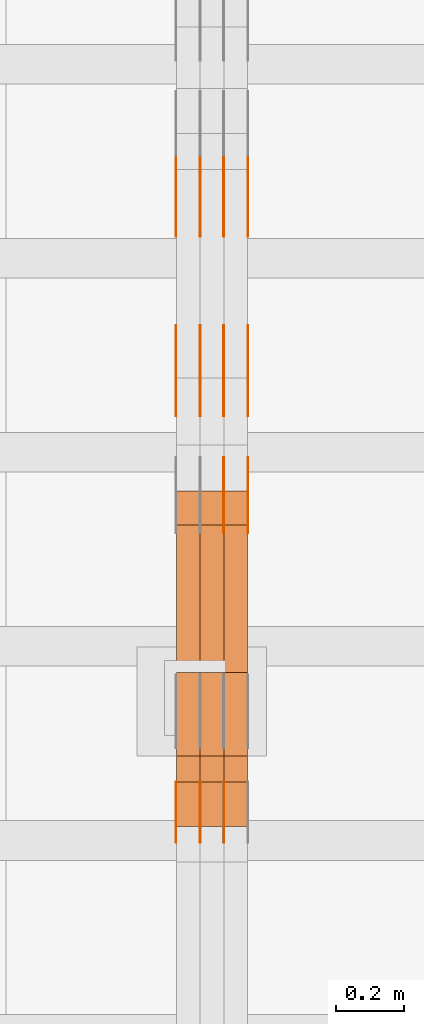
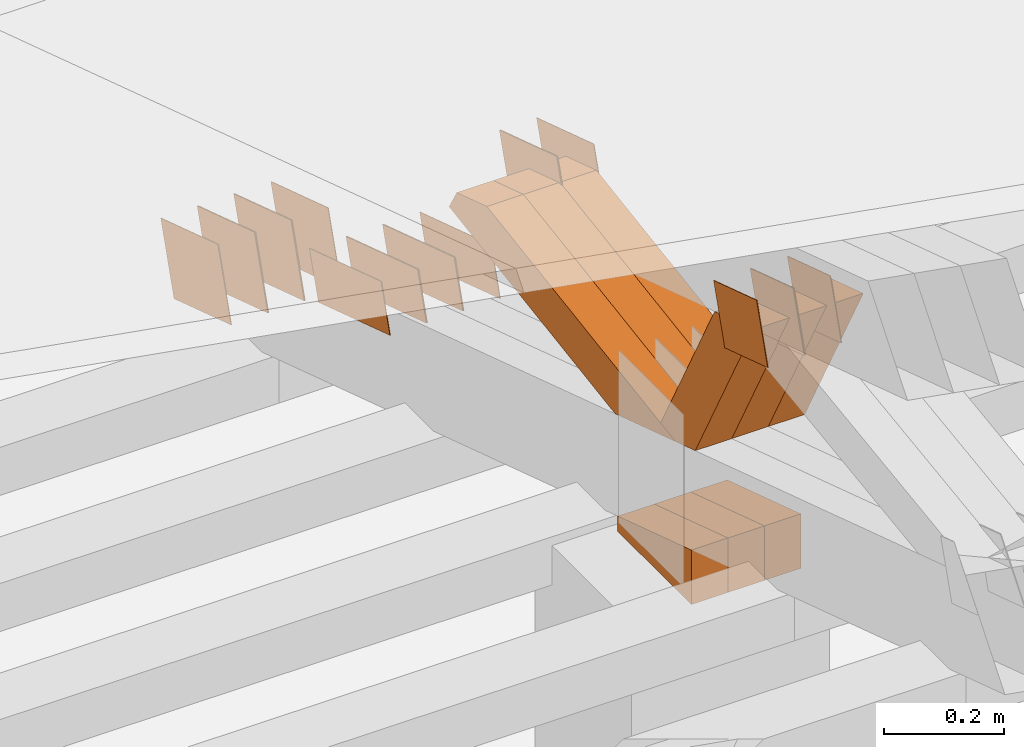
# One storey, part 301 of 385: 28 proxies.
"""IFC2X3 building model written with IfcOpenShell, lengths in millimetres."""

from ifc_helpers import new_model, entity, si_unit, converted_unit, derived_unit, direction, frame, origin, place, context, subcontext, project, spatial, polyline, outline, extrude, source, transform, mapped, material, type_object, type_shapes, element, save


model = new_model("IFC2X3")

# Units and contexts
model_context = context("Model", 3, precision=0.01, world=origin(), true_north=direction((6.12303176911189e-17, 1.0)))
body_context = subcontext(model_context, "Body", "Model", "MODEL_VIEW")
ifc_project = project(units=[si_unit("LENGTHUNIT", "METRE", prefix="MILLI"), si_unit("AREAUNIT", "SQUARE_METRE"), si_unit("VOLUMEUNIT", "CUBIC_METRE"), converted_unit("PLANEANGLEUNIT", "DEGREE", entity("IfcRatioMeasure", 0.0174532925199433), si_unit("PLANEANGLEUNIT", "RADIAN"), dimensions=[0, 0, 0, 0, 0, 0, 0]), si_unit("MASSUNIT", "GRAM", prefix="KILO"), derived_unit("MASSDENSITYUNIT", [(si_unit("MASSUNIT", "GRAM", prefix="KILO"), 1), (si_unit("LENGTHUNIT", "METRE"), -3)]), si_unit("TIMEUNIT", "SECOND"), si_unit("FREQUENCYUNIT", "HERTZ"), si_unit("THERMODYNAMICTEMPERATUREUNIT", "DEGREE_CELSIUS"), derived_unit("THERMALTRANSMITTANCEUNIT", [(si_unit("MASSUNIT", "GRAM", prefix="KILO"), 1), (si_unit("THERMODYNAMICTEMPERATUREUNIT", "KELVIN"), -1), (si_unit("TIMEUNIT", "SECOND"), -3)]), derived_unit("VOLUMETRICFLOWRATEUNIT", [(si_unit("LENGTHUNIT", "METRE"), 3), (si_unit("TIMEUNIT", "SECOND"), -1)]), si_unit("ELECTRICCURRENTUNIT", "AMPERE"), si_unit("ELECTRICVOLTAGEUNIT", "VOLT"), si_unit("POWERUNIT", "WATT"), si_unit("FORCEUNIT", "NEWTON", prefix="KILO"), si_unit("ILLUMINANCEUNIT", "LUX"), si_unit("LUMINOUSFLUXUNIT", "LUMEN"), si_unit("LUMINOUSINTENSITYUNIT", "CANDELA"), derived_unit("USERDEFINED", [(si_unit("MASSUNIT", "GRAM", prefix="KILO"), -1), (si_unit("LENGTHUNIT", "METRE"), -2), (si_unit("TIMEUNIT", "SECOND"), 3), (si_unit("LUMINOUSFLUXUNIT", "LUMEN"), 1)]), derived_unit("LINEARVELOCITYUNIT", [(si_unit("LENGTHUNIT", "METRE"), 1), (si_unit("TIMEUNIT", "SECOND"), -1)]), si_unit("PRESSUREUNIT", "PASCAL"), derived_unit("USERDEFINED", [(si_unit("LENGTHUNIT", "METRE"), -2), (si_unit("MASSUNIT", "GRAM", prefix="KILO"), 1), (si_unit("TIMEUNIT", "SECOND"), -2)])], contexts=[model_context])

# Site, building, storey
site_placement = place(None, origin())
site = spatial("IfcSite", under=ifc_project, at=site_placement, CompositionType="ELEMENT")
building_placement = place(site_placement, origin())
building = spatial("IfcBuilding", under=site, at=building_placement, CompositionType="ELEMENT")
storey_placement = place(building_placement, origin())
storey = spatial("IfcBuildingStorey", under=building, at=storey_placement, Name="Default", CompositionType="ELEMENT", Elevation=0.0)

# Proxies
ifc_material_1 = material(Name="IfcSurfaceStyle #514582")
building_element_proxy_type_1 = type_object("IfcBuildingElementProxyType", PredefinedType="NOTDEFINED", material=ifc_material_1)
shared_shape_1 = source(origin(), body_context, "Body", "SweptSolid", [
    extrude(outline(polyline([(-125.00031378339, -47.9999612158856), (125.000225258022, -47.9999612158856), (124.999811678525, 47.9999612158856), (-124.999723153156, 47.9999612158856), (-125.00031378339, -47.9999612158856)])), frame((125.000225258022, 48.0000091013474, 0.0), z_axis=(0.0, 0.0, 1.0), x_axis=(-1.0, 0.0, 0.0)), (0.0, 0.0, 1.0), 1.3),
])
type_shapes(building_element_proxy_type_1, [shared_shape_1])
proxy_1_placement = place(building_placement, frame((42386.3, 18456.8597683375, 2657.46691321253), z_axis=(-1.0, 0.0, 0.0), x_axis=(0.0, -0.951056516295124, 0.309016994375039)))
element("IfcBuildingElementProxy", 1, at=proxy_1_placement, inside=storey, type_object=building_element_proxy_type_1, material=ifc_material_1, context=body_context, shape_type="MappedRepresentation", body=[
    mapped(shared_shape_1, transform((0.0, 0.0, 0.0), scale=1.0)),
])
ifc_material_2 = material(Name="IfcSurfaceStyle #514525")
building_element_proxy_type_2 = type_object("IfcBuildingElementProxyType", PredefinedType="NOTDEFINED", material=ifc_material_2)
shared_shape_2 = source(origin(), body_context, "Body", "SweptSolid", [
    extrude(outline(polyline([(-125.00031378339, -47.9999612158856), (125.000225258022, -47.9999612158856), (124.999811678525, 47.9999612158856), (-124.999723153156, 47.9999612158856), (-125.00031378339, -47.9999612158856)])), frame((125.000225258022, 48.0000091013474, 0.0), z_axis=(0.0, 0.0, 1.0), x_axis=(-1.0, 0.0, 0.0)), (0.0, 0.0, 1.0), 1.3),
])
type_shapes(building_element_proxy_type_2, [shared_shape_2])
proxy_2_placement = place(building_placement, frame((42315.0, 18456.8597683375, 2657.46691321253), z_axis=(-1.0, 0.0, 0.0), x_axis=(0.0, -0.951056516295124, 0.309016994375039)))
element("IfcBuildingElementProxy", 2, at=proxy_2_placement, inside=storey, type_object=building_element_proxy_type_2, material=ifc_material_2, context=body_context, shape_type="MappedRepresentation", body=[
    mapped(shared_shape_2, transform((0.0, 0.0, 0.0), scale=1.0)),
])
ifc_material_3 = material(Name="IfcSurfaceStyle #514468")
building_element_proxy_type_3 = type_object("IfcBuildingElementProxyType", PredefinedType="NOTDEFINED", material=ifc_material_3)
shared_shape_3 = source(origin(), body_context, "Body", "SweptSolid", [
    extrude(outline(polyline([(-125.00031378339, -47.9999612158856), (125.000225258022, -47.9999612158856), (124.999811678525, 47.9999612158856), (-124.999723153156, 47.9999612158856), (-125.00031378339, -47.9999612158856)])), frame((125.000225258022, 48.0000091013474, 0.0), z_axis=(0.0, 0.0, 1.0), x_axis=(-1.0, 0.0, 0.0)), (0.0, 0.0, 1.0), 1.3),
])
type_shapes(building_element_proxy_type_3, [shared_shape_3])
proxy_3_placement = place(building_placement, frame((42316.3, 18456.8597683375, 2657.46691321253), z_axis=(-1.0, 0.0, 0.0), x_axis=(0.0, -0.951056516295124, 0.309016994375039)))
element("IfcBuildingElementProxy", 3, at=proxy_3_placement, inside=storey, type_object=building_element_proxy_type_3, material=ifc_material_3, context=body_context, shape_type="MappedRepresentation", body=[
    mapped(shared_shape_3, transform((0.0, 0.0, 0.0), scale=1.0)),
])
ifc_material_4 = material(Name="IfcSurfaceStyle #514411")
building_element_proxy_type_4 = type_object("IfcBuildingElementProxyType", PredefinedType="NOTDEFINED", material=ifc_material_4)
shared_shape_4 = source(origin(), body_context, "Body", "SweptSolid", [
    extrude(outline(polyline([(-125.00031378339, -47.9999612158856), (125.000225258022, -47.9999612158856), (124.999811678525, 47.9999612158856), (-124.999723153156, 47.9999612158856), (-125.00031378339, -47.9999612158856)])), frame((125.000225258022, 48.0000091013474, 0.0), z_axis=(0.0, 0.0, 1.0), x_axis=(-1.0, 0.0, 0.0)), (0.0, 0.0, 1.0), 1.29999999999998),
])
type_shapes(building_element_proxy_type_4, [shared_shape_4])
proxy_4_placement = place(building_placement, frame((42245.0, 18456.8597683375, 2657.46691321253), z_axis=(-1.0, 0.0, 0.0), x_axis=(0.0, -0.951056516295124, 0.309016994375039)))
element("IfcBuildingElementProxy", 4, at=proxy_4_placement, inside=storey, type_object=building_element_proxy_type_4, material=ifc_material_4, context=body_context, shape_type="MappedRepresentation", body=[
    mapped(shared_shape_4, transform((0.0, 0.0, 0.0), scale=1.0)),
])
ifc_material_5 = material(Name="IfcSurfaceStyle #514354")
building_element_proxy_type_5 = type_object("IfcBuildingElementProxyType", PredefinedType="NOTDEFINED", material=ifc_material_5)
shared_shape_5 = source(origin(), body_context, "Body", "SweptSolid", [
    extrude(outline(polyline([(-125.00031378339, -47.9999612158856), (125.000225258022, -47.9999612158856), (124.999811678525, 47.9999612158856), (-124.999723153156, 47.9999612158856), (-125.00031378339, -47.9999612158856)])), frame((125.000225258022, 48.0000091013474, 0.0), z_axis=(0.0, 0.0, 1.0), x_axis=(-1.0, 0.0, 0.0)), (0.0, 0.0, 1.0), 1.29999999999998),
])
type_shapes(building_element_proxy_type_5, [shared_shape_5])
proxy_5_placement = place(building_placement, frame((42246.3, 18456.8597683375, 2657.46691321253), z_axis=(-1.0, 0.0, 0.0), x_axis=(0.0, -0.951056516295124, 0.309016994375039)))
element("IfcBuildingElementProxy", 5, at=proxy_5_placement, inside=storey, type_object=building_element_proxy_type_5, material=ifc_material_5, context=body_context, shape_type="MappedRepresentation", body=[
    mapped(shared_shape_5, transform((0.0, 0.0, 0.0), scale=1.0)),
])
ifc_material_6 = material(Name="IfcSurfaceStyle #514297")
building_element_proxy_type_6 = type_object("IfcBuildingElementProxyType", PredefinedType="NOTDEFINED", material=ifc_material_6)
shared_shape_6 = source(origin(), body_context, "Body", "SweptSolid", [
    extrude(outline(polyline([(-125.00031378339, -47.9999612158856), (125.000225258022, -47.9999612158856), (124.999811678525, 47.9999612158856), (-124.999723153156, 47.9999612158856), (-125.00031378339, -47.9999612158856)])), frame((125.000225258022, 48.0000091013474, 0.0), z_axis=(0.0, 0.0, 1.0), x_axis=(-1.0, 0.0, 0.0)), (0.0, 0.0, 1.0), 1.29999999999998),
])
type_shapes(building_element_proxy_type_6, [shared_shape_6])
proxy_6_placement = place(building_placement, frame((42175.0, 18456.8597683375, 2657.46691321253), z_axis=(-1.0, 0.0, 0.0), x_axis=(0.0, -0.951056516295124, 0.309016994375039)))
element("IfcBuildingElementProxy", 6, at=proxy_6_placement, inside=storey, type_object=building_element_proxy_type_6, material=ifc_material_6, context=body_context, shape_type="MappedRepresentation", body=[
    mapped(shared_shape_6, transform((0.0, 0.0, 0.0), scale=1.0)),
])
ifc_material_7 = material(Name="IfcSurfaceStyle #512872")
building_element_proxy_type_7 = type_object("IfcBuildingElementProxyType", PredefinedType="NOTDEFINED", material=ifc_material_7)
shared_shape_7 = source(origin(), body_context, "Body", "SweptSolid", [
    extrude(outline(polyline([(-99.999796294464, -72.0000050220467), (99.9998768370438, -72.0000050220467), (100.000260677528, 72.0000050220467), (-100.000341220108, 72.0000050220467), (-99.999796294464, -72.0000050220467)])), frame((100.000260677528, 72.0000050220467, 0.0), z_axis=(0.0, 0.0, 1.0), x_axis=(-1.0, 0.0, 0.0)), (0.0, 0.0, 1.0), 1.3),
])
type_shapes(building_element_proxy_type_7, [shared_shape_7])
proxy_7_placement = place(building_placement, frame((42386.3, 18936.3876569477, 2373.90613192527), z_axis=(-1.0, 0.0, 0.0), x_axis=(0.0, -0.951056516295124, 0.309016994375039)))
element("IfcBuildingElementProxy", 7, at=proxy_7_placement, inside=storey, type_object=building_element_proxy_type_7, material=ifc_material_7, context=body_context, shape_type="MappedRepresentation", body=[
    mapped(shared_shape_7, transform((0.0, 0.0, 0.0), scale=1.0)),
])
ifc_material_8 = material(Name="IfcSurfaceStyle #512815")
building_element_proxy_type_8 = type_object("IfcBuildingElementProxyType", PredefinedType="NOTDEFINED", material=ifc_material_8)
shared_shape_8 = source(origin(), body_context, "Body", "SweptSolid", [
    extrude(outline(polyline([(-99.999796294464, -72.0000050220467), (99.9998768370438, -72.0000050220467), (100.000260677528, 72.0000050220467), (-100.000341220108, 72.0000050220467), (-99.999796294464, -72.0000050220467)])), frame((100.000260677528, 72.0000050220467, 0.0), z_axis=(0.0, 0.0, 1.0), x_axis=(-1.0, 0.0, 0.0)), (0.0, 0.0, 1.0), 1.3),
])
type_shapes(building_element_proxy_type_8, [shared_shape_8])
proxy_8_placement = place(building_placement, frame((42315.0, 18936.3876569477, 2373.90613192527), z_axis=(-1.0, 0.0, 0.0), x_axis=(0.0, -0.951056516295124, 0.309016994375039)))
element("IfcBuildingElementProxy", 8, at=proxy_8_placement, inside=storey, type_object=building_element_proxy_type_8, material=ifc_material_8, context=body_context, shape_type="MappedRepresentation", body=[
    mapped(shared_shape_8, transform((0.0, 0.0, 0.0), scale=1.0)),
])
ifc_material_9 = material(Name="IfcSurfaceStyle #512758")
building_element_proxy_type_9 = type_object("IfcBuildingElementProxyType", PredefinedType="NOTDEFINED", material=ifc_material_9)
shared_shape_9 = source(origin(), body_context, "Body", "SweptSolid", [
    extrude(outline(polyline([(-99.999796294464, -72.0000050220467), (99.9998768370438, -72.0000050220467), (100.000260677528, 72.0000050220467), (-100.000341220108, 72.0000050220467), (-99.999796294464, -72.0000050220467)])), frame((100.000260677528, 72.0000050220467, 0.0), z_axis=(0.0, 0.0, 1.0), x_axis=(-1.0, 0.0, 0.0)), (0.0, 0.0, 1.0), 1.3),
])
type_shapes(building_element_proxy_type_9, [shared_shape_9])
proxy_9_placement = place(building_placement, frame((42316.3, 18936.3876569477, 2373.90613192527), z_axis=(-1.0, 0.0, 0.0), x_axis=(0.0, -0.951056516295124, 0.309016994375039)))
element("IfcBuildingElementProxy", 9, at=proxy_9_placement, inside=storey, type_object=building_element_proxy_type_9, material=ifc_material_9, context=body_context, shape_type="MappedRepresentation", body=[
    mapped(shared_shape_9, transform((0.0, 0.0, 0.0), scale=1.0)),
])
ifc_material_10 = material(Name="IfcSurfaceStyle #512701")
building_element_proxy_type_10 = type_object("IfcBuildingElementProxyType", PredefinedType="NOTDEFINED", material=ifc_material_10)
shared_shape_10 = source(origin(), body_context, "Body", "SweptSolid", [
    extrude(outline(polyline([(-99.999796294464, -72.0000050220467), (99.9998768370438, -72.0000050220467), (100.000260677528, 72.0000050220467), (-100.000341220108, 72.0000050220467), (-99.999796294464, -72.0000050220467)])), frame((100.000260677528, 72.0000050220467, 0.0), z_axis=(0.0, 0.0, 1.0), x_axis=(-1.0, 0.0, 0.0)), (0.0, 0.0, 1.0), 1.29999999999998),
])
type_shapes(building_element_proxy_type_10, [shared_shape_10])
proxy_10_placement = place(building_placement, frame((42245.0, 18936.3876569477, 2373.90613192527), z_axis=(-1.0, 0.0, 0.0), x_axis=(0.0, -0.951056516295124, 0.309016994375039)))
element("IfcBuildingElementProxy", 10, at=proxy_10_placement, inside=storey, type_object=building_element_proxy_type_10, material=ifc_material_10, context=body_context, shape_type="MappedRepresentation", body=[
    mapped(shared_shape_10, transform((0.0, 0.0, 0.0), scale=1.0)),
])
ifc_material_11 = material(Name="IfcSurfaceStyle #512644")
building_element_proxy_type_11 = type_object("IfcBuildingElementProxyType", PredefinedType="NOTDEFINED", material=ifc_material_11)
shared_shape_11 = source(origin(), body_context, "Body", "SweptSolid", [
    extrude(outline(polyline([(-99.999796294464, -72.0000050220467), (99.9998768370438, -72.0000050220467), (100.000260677528, 72.0000050220467), (-100.000341220108, 72.0000050220467), (-99.999796294464, -72.0000050220467)])), frame((100.000260677528, 72.0000050220467, 0.0), z_axis=(0.0, 0.0, 1.0), x_axis=(-1.0, 0.0, 0.0)), (0.0, 0.0, 1.0), 1.29999999999998),
])
type_shapes(building_element_proxy_type_11, [shared_shape_11])
proxy_11_placement = place(building_placement, frame((42246.3, 18936.3876569477, 2373.90613192527), z_axis=(-1.0, 0.0, 0.0), x_axis=(0.0, -0.951056516295124, 0.309016994375039)))
element("IfcBuildingElementProxy", 11, at=proxy_11_placement, inside=storey, type_object=building_element_proxy_type_11, material=ifc_material_11, context=body_context, shape_type="MappedRepresentation", body=[
    mapped(shared_shape_11, transform((0.0, 0.0, 0.0), scale=1.0)),
])
ifc_material_12 = material(Name="IfcSurfaceStyle #512587")
building_element_proxy_type_12 = type_object("IfcBuildingElementProxyType", PredefinedType="NOTDEFINED", material=ifc_material_12)
shared_shape_12 = source(origin(), body_context, "Body", "SweptSolid", [
    extrude(outline(polyline([(-99.999796294464, -72.0000050220467), (99.9998768370438, -72.0000050220467), (100.000260677528, 72.0000050220467), (-100.000341220108, 72.0000050220467), (-99.999796294464, -72.0000050220467)])), frame((100.000260677528, 72.0000050220467, 0.0), z_axis=(0.0, 0.0, 1.0), x_axis=(-1.0, 0.0, 0.0)), (0.0, 0.0, 1.0), 1.29999999999999),
])
type_shapes(building_element_proxy_type_12, [shared_shape_12])
proxy_12_placement = place(building_placement, frame((42175.0, 18936.3876569477, 2373.90613192527), z_axis=(-1.0, 0.0, 0.0), x_axis=(0.0, -0.951056516295124, 0.309016994375039)))
element("IfcBuildingElementProxy", 12, at=proxy_12_placement, inside=storey, type_object=building_element_proxy_type_12, material=ifc_material_12, context=body_context, shape_type="MappedRepresentation", body=[
    mapped(shared_shape_12, transform((0.0, 0.0, 0.0), scale=1.0)),
])
ifc_material_13 = material(Name="IfcSurfaceStyle #508996")
building_element_proxy_type_13 = type_object("IfcBuildingElementProxyType", PredefinedType="NOTDEFINED", material=ifc_material_13)
shared_shape_13 = source(origin(), body_context, "Body", "SweptSolid", [
    extrude(outline(polyline([(-74.9998605591058, -59.9999264677524), (74.999875428623, -59.9999264677524), (74.9998605591068, 59.9999264677524), (-74.9998754286239, 59.9999264677524), (-74.9998605591058, -59.9999264677524)])), frame((75.0002460484325, 60.0000016373508, 0.0), z_axis=(0.0, 0.0, 1.0), x_axis=(-1.0, 0.0, 0.0)), (0.0, 0.0, 1.0), 1.3),
])
type_shapes(building_element_proxy_type_13, [shared_shape_13])
proxy_13_placement = place(building_placement, frame((42316.3, 17107.0599369346, 3383.82825001787), z_axis=(-1.0, 0.0, 0.0), x_axis=(0.0, -0.951056516295154, 0.309016994374948)))
element("IfcBuildingElementProxy", 13, at=proxy_13_placement, inside=storey, type_object=building_element_proxy_type_13, material=ifc_material_13, context=body_context, shape_type="MappedRepresentation", body=[
    mapped(shared_shape_13, transform((0.0, 0.0, 0.0), scale=1.0)),
])
ifc_material_14 = material(Name="IfcSurfaceStyle #508939")
building_element_proxy_type_14 = type_object("IfcBuildingElementProxyType", PredefinedType="NOTDEFINED", material=ifc_material_14)
shared_shape_14 = source(origin(), body_context, "Body", "SweptSolid", [
    extrude(outline(polyline([(-74.9998605591058, -59.9999264677524), (74.999875428623, -59.9999264677524), (74.9998605591068, 59.9999264677524), (-74.9998754286239, 59.9999264677524), (-74.9998605591058, -59.9999264677524)])), frame((75.0002460484325, 60.0000016373508, 0.0), z_axis=(0.0, 0.0, 1.0), x_axis=(-1.0, 0.0, 0.0)), (0.0, 0.0, 1.0), 1.29999999999999),
])
type_shapes(building_element_proxy_type_14, [shared_shape_14])
proxy_14_placement = place(building_placement, frame((42245.0, 17107.0599369346, 3383.82825001787), z_axis=(-1.0, 0.0, 0.0), x_axis=(0.0, -0.951056516295154, 0.309016994374948)))
element("IfcBuildingElementProxy", 14, at=proxy_14_placement, inside=storey, type_object=building_element_proxy_type_14, material=ifc_material_14, context=body_context, shape_type="MappedRepresentation", body=[
    mapped(shared_shape_14, transform((0.0, 0.0, 0.0), scale=1.0)),
])
ifc_material_15 = material(Name="IfcSurfaceStyle #508882")
building_element_proxy_type_15 = type_object("IfcBuildingElementProxyType", PredefinedType="NOTDEFINED", material=ifc_material_15)
shared_shape_15 = source(origin(), body_context, "Body", "SweptSolid", [
    extrude(outline(polyline([(-74.9998605591058, -59.9999264677524), (74.999875428623, -59.9999264677524), (74.9998605591068, 59.9999264677524), (-74.9998754286239, 59.9999264677524), (-74.9998605591058, -59.9999264677524)])), frame((75.0002460484325, 60.0000016373508, 0.0), z_axis=(0.0, 0.0, 1.0), x_axis=(-1.0, 0.0, 0.0)), (0.0, 0.0, 1.0), 1.29999999999999),
])
type_shapes(building_element_proxy_type_15, [shared_shape_15])
proxy_15_placement = place(building_placement, frame((42246.3, 17107.0599369346, 3383.82825001787), z_axis=(-1.0, 0.0, 0.0), x_axis=(0.0, -0.951056516295154, 0.309016994374948)))
element("IfcBuildingElementProxy", 15, at=proxy_15_placement, inside=storey, type_object=building_element_proxy_type_15, material=ifc_material_15, context=body_context, shape_type="MappedRepresentation", body=[
    mapped(shared_shape_15, transform((0.0, 0.0, 0.0), scale=1.0)),
])
ifc_material_16 = material(Name="IfcSurfaceStyle #508825")
building_element_proxy_type_16 = type_object("IfcBuildingElementProxyType", PredefinedType="NOTDEFINED", material=ifc_material_16)
shared_shape_16 = source(origin(), body_context, "Body", "SweptSolid", [
    extrude(outline(polyline([(-74.9998605591058, -59.9999264677524), (74.999875428623, -59.9999264677524), (74.9998605591068, 59.9999264677524), (-74.9998754286239, 59.9999264677524), (-74.9998605591058, -59.9999264677524)])), frame((75.0002460484325, 60.0000016373508, 0.0), z_axis=(0.0, 0.0, 1.0), x_axis=(-1.0, 0.0, 0.0)), (0.0, 0.0, 1.0), 1.29999999999999),
])
type_shapes(building_element_proxy_type_16, [shared_shape_16])
proxy_16_placement = place(building_placement, frame((42175.0, 17107.0599369346, 3383.82825001787), z_axis=(-1.0, 0.0, 0.0), x_axis=(0.0, -0.951056516295154, 0.309016994374948)))
element("IfcBuildingElementProxy", 16, at=proxy_16_placement, inside=storey, type_object=building_element_proxy_type_16, material=ifc_material_16, context=body_context, shape_type="MappedRepresentation", body=[
    mapped(shared_shape_16, transform((0.0, 0.0, 0.0), scale=1.0)),
])
ifc_material_17 = material(Name="IfcSurfaceStyle #508426")
building_element_proxy_type_17 = type_object("IfcBuildingElementProxyType", PredefinedType="NOTDEFINED", material=ifc_material_17)
shared_shape_17 = source(origin(), body_context, "Body", "SweptSolid", [
    extrude(outline(polyline([(-99.9999427841299, -54.0000599375792), (99.9996549037756, -54.0000599375792), (100.000407167194, 54.0000599375792), (-100.00011928684, 54.0000599375792), (-99.9999427841299, -54.0000599375792)])), frame((100.000407167194, 54.0000599375792, 0.0), z_axis=(0.0, 0.0, 1.0), x_axis=(-1.0, 0.0, 0.0)), (0.0, 0.0, 1.0), 1.3),
])
type_shapes(building_element_proxy_type_17, [shared_shape_17])
proxy_17_placement = place(building_placement, frame((42386.3, 18065.0682492591, 3072.55239547302), z_axis=(-1.0, 0.0, 0.0), x_axis=(0.0, -0.951056516295154, 0.309016994374948)))
element("IfcBuildingElementProxy", 17, at=proxy_17_placement, inside=storey, type_object=building_element_proxy_type_17, material=ifc_material_17, context=body_context, shape_type="MappedRepresentation", body=[
    mapped(shared_shape_17, transform((0.0, 0.0, 0.0), scale=1.0)),
])
ifc_material_18 = material(Name="IfcSurfaceStyle #508369")
building_element_proxy_type_18 = type_object("IfcBuildingElementProxyType", PredefinedType="NOTDEFINED", material=ifc_material_18)
shared_shape_18 = source(origin(), body_context, "Body", "SweptSolid", [
    extrude(outline(polyline([(-99.9999427841299, -54.0000599375792), (99.9996549037756, -54.0000599375792), (100.000407167194, 54.0000599375792), (-100.00011928684, 54.0000599375792), (-99.9999427841299, -54.0000599375792)])), frame((100.000407167194, 54.0000599375792, 0.0), z_axis=(0.0, 0.0, 1.0), x_axis=(-1.0, 0.0, 0.0)), (0.0, 0.0, 1.0), 1.3),
])
type_shapes(building_element_proxy_type_18, [shared_shape_18])
proxy_18_placement = place(building_placement, frame((42315.0, 18065.0682492591, 3072.55239547302), z_axis=(-1.0, 0.0, 0.0), x_axis=(0.0, -0.951056516295154, 0.309016994374948)))
element("IfcBuildingElementProxy", 18, at=proxy_18_placement, inside=storey, type_object=building_element_proxy_type_18, material=ifc_material_18, context=body_context, shape_type="MappedRepresentation", body=[
    mapped(shared_shape_18, transform((0.0, 0.0, 0.0), scale=1.0)),
])
ifc_material_19 = material(Name="IfcSurfaceStyle #508312")
building_element_proxy_type_19 = type_object("IfcBuildingElementProxyType", PredefinedType="NOTDEFINED", material=ifc_material_19)
shared_shape_19 = source(origin(), body_context, "Body", "SweptSolid", [
    extrude(outline(polyline([(-99.9999427841299, -54.0000599375792), (99.9996549037756, -54.0000599375792), (100.000407167194, 54.0000599375792), (-100.00011928684, 54.0000599375792), (-99.9999427841299, -54.0000599375792)])), frame((100.000407167194, 54.0000599375792, 0.0), z_axis=(0.0, 0.0, 1.0), x_axis=(-1.0, 0.0, 0.0)), (0.0, 0.0, 1.0), 1.3),
])
type_shapes(building_element_proxy_type_19, [shared_shape_19])
proxy_19_placement = place(building_placement, frame((42316.3, 18065.0682492591, 3072.55239547302), z_axis=(-1.0, 0.0, 0.0), x_axis=(0.0, -0.951056516295154, 0.309016994374948)))
element("IfcBuildingElementProxy", 19, at=proxy_19_placement, inside=storey, type_object=building_element_proxy_type_19, material=ifc_material_19, context=body_context, shape_type="MappedRepresentation", body=[
    mapped(shared_shape_19, transform((0.0, 0.0, 0.0), scale=1.0)),
])
ifc_material_20 = material(Name="IfcSurfaceStyle #500821")
building_element_proxy_type_20 = type_object("IfcBuildingElementProxyType", Name="T1-E1 500819", PredefinedType="NOTDEFINED", material=ifc_material_20)
shared_shape_20 = source(origin(), body_context, "Body", "SweptSolid", [
    extrude(outline(polyline([(4.4675903320374, -122.500000000001), (35.3350219726624, -122.500000000001), (35.3350219726501, 122.500000000001), (-75.1376342773499, 122.500000000001), (4.4675903320374, -122.500000000001)])), frame((35.3350219726624, 122.50000005215, 0.0), z_axis=(0.0, 0.0, 1.0), x_axis=(-1.0, 0.0, 0.0)), (0.0, 0.0, 1.0), 70.0),
])
type_shapes(building_element_proxy_type_20, [shared_shape_20])
proxy_20_placement = place(building_placement, frame((42385.0, 17220.0, 2794.30932617186), z_axis=(-1.0, 0.0, 0.0), x_axis=(0.0, 0.0, 1.0)))
element("IfcBuildingElementProxy", 20, at=proxy_20_placement, inside=storey, type_object=building_element_proxy_type_20, material=ifc_material_20, Name="T1-E1", context=body_context, shape_type="MappedRepresentation", body=[
    mapped(shared_shape_20, transform((0.0, 0.0, 0.0), scale=1.0)),
])
ifc_material_21 = material(Name="IfcSurfaceStyle #500764")
building_element_proxy_type_21 = type_object("IfcBuildingElementProxyType", Name="T1-E1 500762", PredefinedType="NOTDEFINED", material=ifc_material_21)
shared_shape_21 = source(origin(), body_context, "Body", "SweptSolid", [
    extrude(outline(polyline([(4.4675903320374, -122.500000000001), (35.3350219726624, -122.500000000001), (35.3350219726501, 122.500000000001), (-75.1376342773499, 122.500000000001), (4.4675903320374, -122.500000000001)])), frame((35.3350219726624, 122.50000005215, 0.0), z_axis=(0.0, 0.0, 1.0), x_axis=(-1.0, 0.0, 0.0)), (0.0, 0.0, 1.0), 70.0),
])
type_shapes(building_element_proxy_type_21, [shared_shape_21])
proxy_21_placement = place(building_placement, frame((42315.0, 17220.0, 2794.30932617186), z_axis=(-1.0, 0.0, 0.0), x_axis=(0.0, 0.0, 1.0)))
element("IfcBuildingElementProxy", 21, at=proxy_21_placement, inside=storey, type_object=building_element_proxy_type_21, material=ifc_material_21, Name="T1-E1", context=body_context, shape_type="MappedRepresentation", body=[
    mapped(shared_shape_21, transform((0.0, 0.0, 0.0), scale=1.0)),
])
ifc_material_22 = material(Name="IfcSurfaceStyle #500707")
building_element_proxy_type_22 = type_object("IfcBuildingElementProxyType", Name="T1-E1 500705", PredefinedType="NOTDEFINED", material=ifc_material_22)
shared_shape_22 = source(origin(), body_context, "Body", "SweptSolid", [
    extrude(outline(polyline([(4.4675903320374, -122.500000000001), (35.3350219726624, -122.500000000001), (35.3350219726501, 122.500000000001), (-75.1376342773499, 122.500000000001), (4.4675903320374, -122.500000000001)])), frame((35.3350219726624, 122.50000005215, 0.0), z_axis=(0.0, 0.0, 1.0), x_axis=(-1.0, 0.0, 0.0)), (0.0, 0.0, 1.0), 70.0),
])
type_shapes(building_element_proxy_type_22, [shared_shape_22])
proxy_22_placement = place(building_placement, frame((42245.0, 17220.0, 2794.30932617186), z_axis=(-1.0, 0.0, 0.0), x_axis=(0.0, 0.0, 1.0)))
element("IfcBuildingElementProxy", 22, at=proxy_22_placement, inside=storey, type_object=building_element_proxy_type_22, material=ifc_material_22, Name="T1-E1", context=body_context, shape_type="MappedRepresentation", body=[
    mapped(shared_shape_22, transform((0.0, 0.0, 0.0), scale=1.0)),
])
ifc_material_23 = material(Name="IfcSurfaceStyle #499066")
building_element_proxy_type_23 = type_object("IfcBuildingElementProxyType", Name="T1-W39 499064", PredefinedType="NOTDEFINED", material=ifc_material_23)
shared_shape_23 = source(origin(), body_context, "Body", "SweptSolid", [
    extrude(outline(polyline([(-191.519946663886, -47.499928106579), (188.32936223763, -47.499928106579), (171.597440144109, 0.000249483340993841), (122.102882529753, 47.4998033649085), (-290.509738247605, 47.4998033649085), (-191.519946663886, -47.499928106579)])), frame((188.329593252001, 47.499957247623, 0.0), z_axis=(0.0, 0.0, 1.0), x_axis=(-1.0, 0.0, 0.0)), (0.0, 0.0, 1.0), 70.0),
])
type_shapes(building_element_proxy_type_23, [shared_shape_23])
proxy_23_placement = place(building_placement, frame((42385.0, 17238.5876916597, 3055.56121424762), z_axis=(-1.0, 0.0, 0.0), x_axis=(0.0, -0.472216932390777, 0.881482370080902)))
element("IfcBuildingElementProxy", 23, at=proxy_23_placement, inside=storey, type_object=building_element_proxy_type_23, material=ifc_material_23, Name="T1-W39", context=body_context, shape_type="MappedRepresentation", body=[
    mapped(shared_shape_23, transform((0.0, 0.0, 0.0), scale=1.0)),
])
ifc_material_24 = material(Name="IfcSurfaceStyle #499000")
building_element_proxy_type_24 = type_object("IfcBuildingElementProxyType", Name="T1-W39 498998", PredefinedType="NOTDEFINED", material=ifc_material_24)
shared_shape_24 = source(origin(), body_context, "Body", "SweptSolid", [
    extrude(outline(polyline([(-191.519946663886, -47.499928106579), (188.32936223763, -47.499928106579), (171.597440144109, 0.000249483340993841), (122.102882529753, 47.4998033649085), (-290.509738247605, 47.4998033649085), (-191.519946663886, -47.499928106579)])), frame((188.329593252001, 47.499957247623, 0.0), z_axis=(0.0, 0.0, 1.0), x_axis=(-1.0, 0.0, 0.0)), (0.0, 0.0, 1.0), 70.0),
])
type_shapes(building_element_proxy_type_24, [shared_shape_24])
proxy_24_placement = place(building_placement, frame((42315.0, 17238.5876916597, 3055.56121424762), z_axis=(-1.0, 0.0, 0.0), x_axis=(0.0, -0.472216932390777, 0.881482370080902)))
element("IfcBuildingElementProxy", 24, at=proxy_24_placement, inside=storey, type_object=building_element_proxy_type_24, material=ifc_material_24, Name="T1-W39", context=body_context, shape_type="MappedRepresentation", body=[
    mapped(shared_shape_24, transform((0.0, 0.0, 0.0), scale=1.0)),
])
ifc_material_25 = material(Name="IfcSurfaceStyle #498934")
building_element_proxy_type_25 = type_object("IfcBuildingElementProxyType", Name="T1-W39 498932", PredefinedType="NOTDEFINED", material=ifc_material_25)
shared_shape_25 = source(origin(), body_context, "Body", "SweptSolid", [
    extrude(outline(polyline([(-191.519946663886, -47.499928106579), (188.32936223763, -47.499928106579), (171.597440144109, 0.000249483340993841), (122.102882529753, 47.4998033649085), (-290.509738247605, 47.4998033649085), (-191.519946663886, -47.499928106579)])), frame((188.329593252001, 47.499957247623, 0.0), z_axis=(0.0, 0.0, 1.0), x_axis=(-1.0, 0.0, 0.0)), (0.0, 0.0, 1.0), 70.0),
])
type_shapes(building_element_proxy_type_25, [shared_shape_25])
proxy_25_placement = place(building_placement, frame((42245.0, 17238.5876916597, 3055.56121424762), z_axis=(-1.0, 0.0, 0.0), x_axis=(0.0, -0.472216932390777, 0.881482370080902)))
element("IfcBuildingElementProxy", 25, at=proxy_25_placement, inside=storey, type_object=building_element_proxy_type_25, material=ifc_material_25, Name="T1-W39", context=body_context, shape_type="MappedRepresentation", body=[
    mapped(shared_shape_25, transform((0.0, 0.0, 0.0), scale=1.0)),
])
ifc_material_26 = material(Name="IfcSurfaceStyle #498670")
building_element_proxy_type_26 = type_object("IfcBuildingElementProxyType", Name="T1-W10 498668", PredefinedType="NOTDEFINED", material=ifc_material_26)
shared_shape_26 = source(origin(), body_context, "Body", "SweptSolid", [
    extrude(outline(polyline([(-459.546036710757, -47.5000436364511), (174.689450869018, -47.5000436364511), (268.831081103959, 0.00011114562912502), (287.286350706789, 47.4999880636365), (-271.260845969009, 47.4999880636366), (-459.546036710757, -47.5000436364511)])), frame((287.286768781132, 47.5001637448091, 0.0), z_axis=(0.0, 0.0, 1.0), x_axis=(-1.0, 0.0, 0.0)), (0.0, 0.0, 1.0), 70.0),
])
type_shapes(building_element_proxy_type_26, [shared_shape_26])
proxy_26_placement = place(building_placement, frame((42385.0, 18025.1410649788, 3112.76453857986), z_axis=(-1.0, 0.0, 0.0), x_axis=(0.0, -0.988299196256916, -0.152527698068035)))
element("IfcBuildingElementProxy", 26, at=proxy_26_placement, inside=storey, type_object=building_element_proxy_type_26, material=ifc_material_26, Name="T1-W10", context=body_context, shape_type="MappedRepresentation", body=[
    mapped(shared_shape_26, transform((0.0, 0.0, 0.0), scale=1.0)),
])
ifc_material_27 = material(Name="IfcSurfaceStyle #498604")
building_element_proxy_type_27 = type_object("IfcBuildingElementProxyType", Name="T1-W10 498602", PredefinedType="NOTDEFINED", material=ifc_material_27)
shared_shape_27 = source(origin(), body_context, "Body", "SweptSolid", [
    extrude(outline(polyline([(-459.546036710757, -47.5000436364511), (174.689450869018, -47.5000436364511), (268.831081103959, 0.00011114562912502), (287.286350706789, 47.4999880636365), (-271.260845969009, 47.4999880636366), (-459.546036710757, -47.5000436364511)])), frame((287.286768781132, 47.5001637448091, 0.0), z_axis=(0.0, 0.0, 1.0), x_axis=(-1.0, 0.0, 0.0)), (0.0, 0.0, 1.0), 70.0),
])
type_shapes(building_element_proxy_type_27, [shared_shape_27])
proxy_27_placement = place(building_placement, frame((42315.0, 18025.1410649788, 3112.76453857986), z_axis=(-1.0, 0.0, 0.0), x_axis=(0.0, -0.988299196256916, -0.152527698068035)))
element("IfcBuildingElementProxy", 27, at=proxy_27_placement, inside=storey, type_object=building_element_proxy_type_27, material=ifc_material_27, Name="T1-W10", context=body_context, shape_type="MappedRepresentation", body=[
    mapped(shared_shape_27, transform((0.0, 0.0, 0.0), scale=1.0)),
])
ifc_material_28 = material(Name="IfcSurfaceStyle #498538")
building_element_proxy_type_28 = type_object("IfcBuildingElementProxyType", Name="T1-W10 498536", PredefinedType="NOTDEFINED", material=ifc_material_28)
shared_shape_28 = source(origin(), body_context, "Body", "SweptSolid", [
    extrude(outline(polyline([(-459.546036710757, -47.5000436364511), (174.689450869018, -47.5000436364511), (268.831081103959, 0.00011114562912502), (287.286350706789, 47.4999880636365), (-271.260845969009, 47.4999880636366), (-459.546036710757, -47.5000436364511)])), frame((287.286768781132, 47.5001637448091, 0.0), z_axis=(0.0, 0.0, 1.0), x_axis=(-1.0, 0.0, 0.0)), (0.0, 0.0, 1.0), 70.0),
])
type_shapes(building_element_proxy_type_28, [shared_shape_28])
proxy_28_placement = place(building_placement, frame((42245.0, 18025.1410649788, 3112.76453857986), z_axis=(-1.0, 0.0, 0.0), x_axis=(0.0, -0.988299196256916, -0.152527698068035)))
element("IfcBuildingElementProxy", 28, at=proxy_28_placement, inside=storey, type_object=building_element_proxy_type_28, material=ifc_material_28, Name="T1-W10", context=body_context, shape_type="MappedRepresentation", body=[
    mapped(shared_shape_28, transform((0.0, 0.0, 0.0), scale=1.0)),
])

save(model, "model.ifc")
